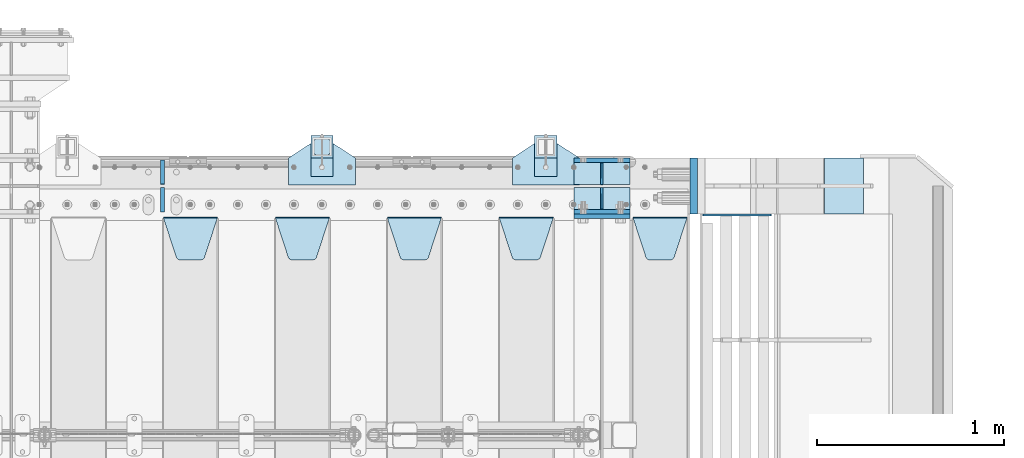
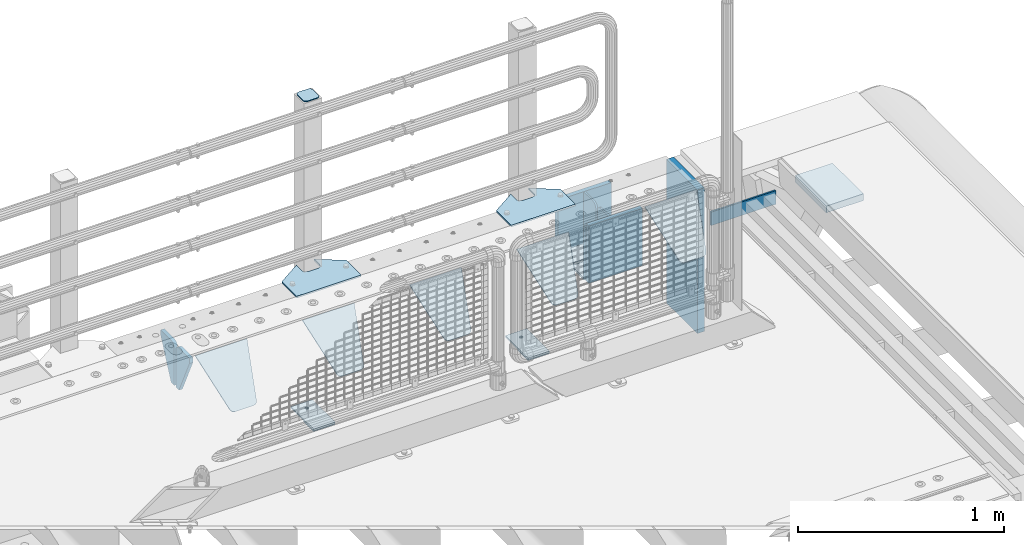
# One storey, part 179 of 193: 24 plates.
"""IFC2X3 building model written with IfcOpenShell, lengths in millimetres."""

from ifc_helpers import new_model, si_unit, frame, origin_with_axes, place, context, subcontext, project, spatial, faceted_brep, material, type_object, element, save


model = new_model("IFC2X3")

# Units and contexts
model_context = context("Model", 3, precision=1e-05, world=origin_with_axes())
body_context = subcontext(model_context, "Body", "Model", "MODEL_VIEW")
ifc_project = project(units=[si_unit("LENGTHUNIT", "METRE", prefix="MILLI"), si_unit("AREAUNIT", "SQUARE_METRE"), si_unit("VOLUMEUNIT", "CUBIC_METRE"), si_unit("MASSUNIT", "GRAM", prefix="KILO"), si_unit("TIMEUNIT", "SECOND"), si_unit("PLANEANGLEUNIT", "RADIAN"), si_unit("SOLIDANGLEUNIT", "STERADIAN"), si_unit("THERMODYNAMICTEMPERATUREUNIT", "DEGREE_CELSIUS"), si_unit("LUMINOUSINTENSITYUNIT", "LUMEN")], contexts=[model_context])

# Site, building, storey
site_placement = place(None, origin_with_axes())
site = spatial("IfcSite", under=ifc_project, at=site_placement, CompositionType="ELEMENT")
building_placement = place(site_placement, origin_with_axes())
building = spatial("IfcBuilding", under=site, at=building_placement, Name="Standard", CompositionType="ELEMENT")
storey_placement = place(building_placement, origin_with_axes())
storey = spatial("IfcBuildingStorey", under=building, at=storey_placement, Name="Undefined", CompositionType="ELEMENT", Elevation=0.0)

# Plates
ifc_material_1 = material(Name="STEEL/S355N")
plate_type_1 = type_object("IfcPlateType", PredefinedType="NOTDEFINED")
for number, where, z_axis, x_axis in (
    (1, (-29045.0, 30137.5, -339.999999999995), (0.0, 0.0, 1.0), (1.0, 0.0, 0.0)),
    (2, (-29045.0, 29862.5, -339.999999999995), (0.0, 0.0, 1.0), (1.0, 0.0, 0.0)),
):
    element("IfcPlate", number, at=place(storey_placement, frame(where, z_axis=z_axis, x_axis=x_axis)), inside=storey, type_object=plate_type_1, material=ifc_material_1, context=body_context, shape_type="Brep", body=[
        faceted_brep([(0.0, -12.5, 0.0), (0.0, -12.5, 310.0), (0.0, 12.5, 310.0), (0.0, 12.5, 0.0), (300.0, -12.5, 310.0), (300.0, 12.5, 310.0), (300.0, -12.5, 0.0), (300.0, 12.5, 0.0)], [[[0, 1, 2, 3]], [[1, 4, 5, 2]], [[4, 6, 7, 5]], [[6, 0, 3, 7]], [[5, 7, 3, 2]], [[6, 4, 1, 0]]]),
    ])
plate_1_placement = place(storey_placement, frame((-29045.0, 29837.5, -340.000000000044), z_axis=(0.0, 0.0, 1.0), x_axis=(1.0, 0.0, 0.0)))
element("IfcPlate", 3, at=plate_1_placement, inside=storey, type_object=plate_type_1, material=ifc_material_1, context=body_context, shape_type="Brep", body=[
    faceted_brep([(0.0, -12.5, 0.0), (9.27684595808387e-10, -12.5, 340.0), (9.27684595808387e-10, 12.5, 340.0), (0.0, 12.5, 0.0), (300.0, -12.5, 340.0), (300.0, 12.5, 340.0), (300.0, -12.5, 0.0), (300.0, 12.5, 0.0)], [[[0, 1, 2, 3]], [[1, 4, 5, 2]], [[4, 6, 7, 5]], [[6, 0, 3, 7]], [[5, 7, 3, 2]], [[6, 4, 1, 0]]]),
])
plate_type_2 = type_object("IfcPlateType", PredefinedType="NOTDEFINED")
for number, where, z_axis, x_axis in (
    (4, (-29045.0, 30008.0, -342.999999999995), (0.0, 1.0, 0.0), (1.0, 0.0, 0.0)),
    (5, (-29045.0, 29992.0, -342.999999999995), (0.0, -1.0, 0.0), (1.0, 0.0, 0.0)),
):
    element("IfcPlate", number, at=place(storey_placement, frame(where, z_axis=z_axis, x_axis=x_axis)), inside=storey, type_object=plate_type_2, material=ifc_material_1, context=body_context, shape_type="Brep", body=[
        faceted_brep([(0.0, -7.0, 0.0), (0.0, -7.0, 117.0), (0.0, 7.0, 117.0), (0.0, 7.0, 0.0), (300.0, -7.0, 117.0), (300.0, 7.0, 117.0), (300.0, -7.0, 0.0), (300.0, 7.0, 0.0)], [[[0, 1, 2, 3]], [[1, 4, 5, 2]], [[4, 6, 7, 5]], [[6, 0, 3, 7]], [[5, 7, 3, 2]], [[6, 4, 1, 0]]]),
    ])
plate_type_3 = type_object("IfcPlateType", PredefinedType="NOTDEFINED")
for number, where, z_axis, x_axis in (
    (6, (-28895.0, 30008.0, -29.9999999999945), (0.0, 0.0, -1.0), (0.0, 1.0, 0.0)),
    (7, (-28895.0, 29992.0, -29.9999999999945), (0.0, 0.0, -1.0), (0.0, -1.0, 0.0)),
):
    element("IfcPlate", number, at=place(storey_placement, frame(where, z_axis=z_axis, x_axis=x_axis)), inside=storey, type_object=plate_type_3, material=ifc_material_1, context=body_context, shape_type="Brep", body=[
        faceted_brep([(0.0, -5.0, 30.0), (0.0, -5.0, 306.0), (0.0, 5.0, 306.0), (0.0, 5.0, 30.0), (117.0, -5.0, 306.0), (117.0, 5.0, 306.0), (117.0, -5.0, 0.0), (117.0, 5.0, 0.0), (30.0, -5.0, 0.0), (30.0, 5.0, 0.0), (24.7905546699913, -5.0, 0.455767409633758), (24.7905546699913, 5.0, 0.455767409633758), (19.7393957002314, -5.0, 1.80922137642275), (19.7393957002314, 5.0, 1.80922137642275), (15.0, -5.0, 4.01923788646684), (15.0, 5.0, 4.01923788646684), (10.7163717094045, -5.0, 7.01866670643066), (10.7163717094045, 5.0, 7.01866670643066), (7.01866670642994, -5.0, 10.7163717094038), (7.01866670642994, 5.0, 10.7163717094038), (4.01923788646673, -5.0, 15.0), (4.01923788646673, 5.0, 15.0), (1.80922137642119, -5.0, 19.7393957002299), (1.80922137642119, 5.0, 19.7393957002299), (0.455767409632244, -5.0, 24.7905546699921), (0.455767409632244, 5.0, 24.7905546699921)], [[[0, 1, 2, 3]], [[1, 4, 5, 2]], [[4, 6, 7, 5]], [[6, 8, 9, 7]], [[8, 10, 11, 9]], [[10, 12, 13, 11]], [[12, 14, 15, 13]], [[14, 16, 17, 15]], [[16, 18, 19, 17]], [[18, 20, 21, 19]], [[20, 22, 23, 21]], [[22, 24, 25, 23]], [[24, 0, 3, 25]], [[5, 7, 9, 11, 13, 15, 17, 19, 21, 23, 25, 3, 2]], [[24, 22, 20, 18, 16, 14, 12, 10, 8, 6, 4, 1, 0]]]),
    ])
plate_type_4 = type_object("IfcPlateType", PredefinedType="NOTDEFINED")
plate_2_placement = place(storey_placement, frame((-28728.0, 29831.767766956, -1.76776695296758), z_axis=(0.0, -0.707106781186547, -0.707106781186548), x_axis=(1.0, 0.0, 0.0)))
element("IfcPlate", 8, at=plate_2_placement, inside=storey, type_object=plate_type_4, material=ifc_material_1, context=body_context, shape_type="Brep", body=[
    faceted_brep([(0.0, -2.5, 0.0), (69.345504679477, -2.50000000000364, 300.171731424831), (69.345504679477, 2.49999999999636, 300.171731424831), (0.0, 2.5, 0.0), (70.9274061199576, -2.50000000000364, 304.897442415397), (70.9274061199576, 2.49999999999636, 304.897442415397), (73.3818627772307, -2.50000000000364, 309.234538108529), (73.3818627772307, 2.49999999999636, 309.234538108529), (76.6187032999551, -2.50000000000728, 313.023683126103), (76.6187032999551, 2.49999999999636, 313.023683126103), (80.5190132704993, -2.50000000000364, 316.125672595372), (80.5190132704993, 2.49999999999636, 316.125672595368), (84.9395038596849, -2.50000000000364, 318.426546230472), (84.9395038596849, 2.49999999999636, 318.426546230476), (89.7177759439219, -2.50000000000364, 319.841774983273), (89.7177759439219, 2.49999999999636, 319.841774983277), (94.678286292652, -2.50000000000364, 320.319366455074), (94.678286292652, 2.49999999999636, 320.319366455074), (195.321713707348, -2.50000000000364, 320.319366455074), (195.321713707348, 2.49999999999636, 320.319366455074), (200.282224056078, -2.50000000000364, 319.841774983273), (200.282224056078, 2.49999999999636, 319.841774983277), (205.060496140315, -2.50000000000364, 318.426546230472), (205.060496140315, 2.49999999999636, 318.426546230472), (209.480986729501, -2.50000000000364, 316.125672595372), (209.480986729501, 2.49999999999636, 316.125672595368), (213.381296700045, -2.50000000000728, 313.023683126103), (213.381296700045, 2.49999999999272, 313.023683126103), (216.618137222769, -2.50000000000364, 309.234538108525), (216.618137222769, 2.49999999999636, 309.234538108522), (219.072593880042, -2.50000000000364, 304.897442415397), (219.072593880042, 2.49999999999636, 304.897442415397), (220.654495320523, -2.50000000000364, 300.171731424831), (220.654495320523, 2.49999999999636, 300.171731424831), (290.0, -2.50000000000364, 0.0), (290.0, 2.49999999999636, 0.0)], [[[0, 1, 2, 3]], [[1, 4, 5, 2]], [[4, 6, 7, 5]], [[6, 8, 9, 7]], [[8, 10, 11, 9]], [[10, 12, 13, 11]], [[12, 14, 15, 13]], [[14, 16, 17, 15]], [[16, 18, 19, 17]], [[18, 20, 21, 19]], [[20, 22, 23, 21]], [[22, 24, 25, 23]], [[24, 26, 27, 25]], [[26, 28, 29, 27]], [[28, 30, 31, 29]], [[30, 32, 33, 31]], [[32, 34, 35, 33]], [[34, 0, 3, 35]], [[5, 7, 9, 11, 13, 15, 17, 19, 21, 23, 25, 27, 29, 31, 33, 35, 3, 2]], [[34, 32, 30, 28, 26, 24, 22, 20, 18, 16, 14, 12, 10, 8, 6, 4, 1, 0]]]),
])
plate_3_placement = place(storey_placement, frame((-29445.0, 29831.767766956, -1.76776695296758), z_axis=(0.0, -0.707106781186547, -0.707106781186548), x_axis=(1.0, 0.0, 0.0)))
element("IfcPlate", 9, at=plate_3_placement, inside=storey, type_object=plate_type_4, material=ifc_material_1, context=body_context, shape_type="Brep", body=[
    faceted_brep([(0.0, -2.5, 0.0), (69.345504679477, -2.50000000000364, 300.171731424831), (69.345504679477, 2.49999999999636, 300.171731424831), (0.0, 2.5, 0.0), (70.9274061199576, -2.50000000000364, 304.897442415397), (70.9274061199576, 2.49999999999636, 304.897442415397), (73.3818627772307, -2.50000000000364, 309.234538108529), (73.3818627772307, 2.49999999999636, 309.234538108529), (76.6187032999551, -2.50000000000728, 313.023683126103), (76.6187032999551, 2.49999999999636, 313.023683126103), (80.5190132704993, -2.50000000000364, 316.125672595372), (80.5190132704993, 2.49999999999636, 316.125672595368), (84.9395038596849, -2.50000000000364, 318.426546230472), (84.9395038596849, 2.49999999999636, 318.426546230476), (89.7177759439219, -2.50000000000364, 319.841774983273), (89.7177759439219, 2.49999999999636, 319.841774983277), (94.678286292652, -2.50000000000364, 320.319366455074), (94.678286292652, 2.49999999999636, 320.319366455074), (195.321713707348, -2.50000000000364, 320.319366455074), (195.321713707348, 2.49999999999636, 320.319366455074), (200.282224056078, -2.50000000000364, 319.841774983273), (200.282224056078, 2.49999999999636, 319.841774983277), (205.060496140315, -2.50000000000364, 318.426546230472), (205.060496140315, 2.49999999999636, 318.426546230472), (209.480986729501, -2.50000000000364, 316.125672595372), (209.480986729501, 2.49999999999636, 316.125672595368), (213.381296700045, -2.50000000000728, 313.023683126103), (213.381296700045, 2.49999999999272, 313.023683126103), (216.618137222769, -2.50000000000364, 309.234538108525), (216.618137222769, 2.49999999999636, 309.234538108522), (219.072593880042, -2.50000000000364, 304.897442415397), (219.072593880042, 2.49999999999636, 304.897442415397), (220.654495320523, -2.50000000000364, 300.171731424831), (220.654495320523, 2.49999999999636, 300.171731424831), (290.0, -2.50000000000364, 0.0), (290.0, 2.49999999999636, 0.0)], [[[0, 1, 2, 3]], [[1, 4, 5, 2]], [[4, 6, 7, 5]], [[6, 8, 9, 7]], [[8, 10, 11, 9]], [[10, 12, 13, 11]], [[12, 14, 15, 13]], [[14, 16, 17, 15]], [[16, 18, 19, 17]], [[18, 20, 21, 19]], [[20, 22, 23, 21]], [[22, 24, 25, 23]], [[24, 26, 27, 25]], [[26, 28, 29, 27]], [[28, 30, 31, 29]], [[30, 32, 33, 31]], [[32, 34, 35, 33]], [[34, 0, 3, 35]], [[5, 7, 9, 11, 13, 15, 17, 19, 21, 23, 25, 27, 29, 31, 33, 35, 3, 2]], [[34, 32, 30, 28, 26, 24, 22, 20, 18, 16, 14, 12, 10, 8, 6, 4, 1, 0]]]),
])
plate_4_placement = place(storey_placement, frame((-30045.0, 29831.767766956, -1.76776695296758), z_axis=(0.0, -0.707106781186547, -0.707106781186548), x_axis=(1.0, 0.0, 0.0)))
element("IfcPlate", 10, at=plate_4_placement, inside=storey, type_object=plate_type_4, material=ifc_material_1, context=body_context, shape_type="Brep", body=[
    faceted_brep([(0.0, -2.5, 0.0), (69.345504679477, -2.50000000000364, 300.171731424831), (69.345504679477, 2.49999999999636, 300.171731424831), (0.0, 2.5, 0.0), (70.9274061199576, -2.50000000000364, 304.897442415397), (70.9274061199576, 2.49999999999636, 304.897442415397), (73.3818627772307, -2.50000000000364, 309.234538108529), (73.3818627772307, 2.49999999999636, 309.234538108529), (76.6187032999551, -2.50000000000728, 313.023683126103), (76.6187032999551, 2.49999999999636, 313.023683126103), (80.5190132704993, -2.50000000000364, 316.125672595372), (80.5190132704993, 2.49999999999636, 316.125672595368), (84.9395038596849, -2.50000000000364, 318.426546230472), (84.9395038596849, 2.49999999999636, 318.426546230476), (89.7177759439219, -2.50000000000364, 319.841774983273), (89.7177759439219, 2.49999999999636, 319.841774983277), (94.678286292652, -2.50000000000364, 320.319366455074), (94.678286292652, 2.49999999999636, 320.319366455074), (195.321713707348, -2.50000000000364, 320.319366455074), (195.321713707348, 2.49999999999636, 320.319366455074), (200.282224056078, -2.50000000000364, 319.841774983273), (200.282224056078, 2.49999999999636, 319.841774983277), (205.060496140315, -2.50000000000364, 318.426546230472), (205.060496140315, 2.49999999999636, 318.426546230472), (209.480986729501, -2.50000000000364, 316.125672595372), (209.480986729501, 2.49999999999636, 316.125672595368), (213.381296700045, -2.50000000000728, 313.023683126103), (213.381296700045, 2.49999999999272, 313.023683126103), (216.618137222769, -2.50000000000364, 309.234538108525), (216.618137222769, 2.49999999999636, 309.234538108522), (219.072593880042, -2.50000000000364, 304.897442415397), (219.072593880042, 2.49999999999636, 304.897442415397), (220.654495320523, -2.50000000000364, 300.171731424831), (220.654495320523, 2.49999999999636, 300.171731424831), (290.0, -2.50000000000364, 0.0), (290.0, 2.49999999999636, 0.0)], [[[0, 1, 2, 3]], [[1, 4, 5, 2]], [[4, 6, 7, 5]], [[6, 8, 9, 7]], [[8, 10, 11, 9]], [[10, 12, 13, 11]], [[12, 14, 15, 13]], [[14, 16, 17, 15]], [[16, 18, 19, 17]], [[18, 20, 21, 19]], [[20, 22, 23, 21]], [[22, 24, 25, 23]], [[24, 26, 27, 25]], [[26, 28, 29, 27]], [[28, 30, 31, 29]], [[30, 32, 33, 31]], [[32, 34, 35, 33]], [[34, 0, 3, 35]], [[5, 7, 9, 11, 13, 15, 17, 19, 21, 23, 25, 27, 29, 31, 33, 35, 3, 2]], [[34, 32, 30, 28, 26, 24, 22, 20, 18, 16, 14, 12, 10, 8, 6, 4, 1, 0]]]),
])
plate_5_placement = place(storey_placement, frame((-30645.0, 29831.767766956, -1.76776695296758), z_axis=(0.0, -0.707106781186547, -0.707106781186548), x_axis=(1.0, 0.0, 0.0)))
element("IfcPlate", 11, at=plate_5_placement, inside=storey, type_object=plate_type_4, material=ifc_material_1, context=body_context, shape_type="Brep", body=[
    faceted_brep([(0.0, -2.5, 0.0), (69.345504679477, -2.50000000000364, 300.171731424831), (69.345504679477, 2.49999999999636, 300.171731424831), (0.0, 2.5, 0.0), (70.9274061199576, -2.50000000000364, 304.897442415397), (70.9274061199576, 2.49999999999636, 304.897442415397), (73.3818627772307, -2.50000000000364, 309.234538108529), (73.3818627772307, 2.49999999999636, 309.234538108529), (76.6187032999551, -2.50000000000728, 313.023683126103), (76.6187032999551, 2.49999999999636, 313.023683126103), (80.5190132704993, -2.50000000000364, 316.125672595372), (80.5190132704993, 2.49999999999636, 316.125672595368), (84.9395038596849, -2.50000000000364, 318.426546230472), (84.9395038596849, 2.49999999999636, 318.426546230476), (89.7177759439219, -2.50000000000364, 319.841774983273), (89.7177759439219, 2.49999999999636, 319.841774983277), (94.678286292652, -2.50000000000364, 320.319366455074), (94.678286292652, 2.49999999999636, 320.319366455074), (195.321713707348, -2.50000000000364, 320.319366455074), (195.321713707348, 2.49999999999636, 320.319366455074), (200.282224056078, -2.50000000000364, 319.841774983273), (200.282224056078, 2.49999999999636, 319.841774983277), (205.060496140315, -2.50000000000364, 318.426546230472), (205.060496140315, 2.49999999999636, 318.426546230472), (209.480986729501, -2.50000000000364, 316.125672595372), (209.480986729501, 2.49999999999636, 316.125672595368), (213.381296700045, -2.50000000000728, 313.023683126103), (213.381296700045, 2.49999999999272, 313.023683126103), (216.618137222769, -2.50000000000364, 309.234538108525), (216.618137222769, 2.49999999999636, 309.234538108522), (219.072593880042, -2.50000000000364, 304.897442415397), (219.072593880042, 2.49999999999636, 304.897442415397), (220.654495320523, -2.50000000000364, 300.171731424831), (220.654495320523, 2.49999999999636, 300.171731424831), (290.0, -2.50000000000364, 0.0), (290.0, 2.49999999999636, 0.0)], [[[0, 1, 2, 3]], [[1, 4, 5, 2]], [[4, 6, 7, 5]], [[6, 8, 9, 7]], [[8, 10, 11, 9]], [[10, 12, 13, 11]], [[12, 14, 15, 13]], [[14, 16, 17, 15]], [[16, 18, 19, 17]], [[18, 20, 21, 19]], [[20, 22, 23, 21]], [[22, 24, 25, 23]], [[24, 26, 27, 25]], [[26, 28, 29, 27]], [[28, 30, 31, 29]], [[30, 32, 33, 31]], [[32, 34, 35, 33]], [[34, 0, 3, 35]], [[5, 7, 9, 11, 13, 15, 17, 19, 21, 23, 25, 27, 29, 31, 33, 35, 3, 2]], [[34, 32, 30, 28, 26, 24, 22, 20, 18, 16, 14, 12, 10, 8, 6, 4, 1, 0]]]),
])
plate_6_placement = place(storey_placement, frame((-31245.0, 29831.767766956, -1.76776695296758), z_axis=(0.0, -0.707106781186547, -0.707106781186548), x_axis=(1.0, 0.0, 0.0)))
element("IfcPlate", 12, at=plate_6_placement, inside=storey, type_object=plate_type_4, material=ifc_material_1, context=body_context, shape_type="Brep", body=[
    faceted_brep([(0.0, -2.5, 0.0), (69.345504679477, -2.50000000000364, 300.171731424831), (69.345504679477, 2.49999999999636, 300.171731424831), (0.0, 2.5, 0.0), (70.9274061199576, -2.50000000000364, 304.897442415397), (70.9274061199576, 2.49999999999636, 304.897442415397), (73.3818627772307, -2.50000000000364, 309.234538108529), (73.3818627772307, 2.49999999999636, 309.234538108529), (76.6187032999551, -2.50000000000728, 313.023683126103), (76.6187032999551, 2.49999999999636, 313.023683126103), (80.5190132704993, -2.50000000000364, 316.125672595372), (80.5190132704993, 2.49999999999636, 316.125672595368), (84.9395038596849, -2.50000000000364, 318.426546230472), (84.9395038596849, 2.49999999999636, 318.426546230476), (89.7177759439219, -2.50000000000364, 319.841774983273), (89.7177759439219, 2.49999999999636, 319.841774983277), (94.678286292652, -2.50000000000364, 320.319366455074), (94.678286292652, 2.49999999999636, 320.319366455074), (195.321713707348, -2.50000000000364, 320.319366455074), (195.321713707348, 2.49999999999636, 320.319366455074), (200.282224056078, -2.50000000000364, 319.841774983273), (200.282224056078, 2.49999999999636, 319.841774983277), (205.060496140315, -2.50000000000364, 318.426546230472), (205.060496140315, 2.49999999999636, 318.426546230472), (209.480986729501, -2.50000000000364, 316.125672595372), (209.480986729501, 2.49999999999636, 316.125672595368), (213.381296700045, -2.50000000000728, 313.023683126103), (213.381296700045, 2.49999999999272, 313.023683126103), (216.618137222769, -2.50000000000364, 309.234538108525), (216.618137222769, 2.49999999999636, 309.234538108522), (219.072593880042, -2.50000000000364, 304.897442415397), (219.072593880042, 2.49999999999636, 304.897442415397), (220.654495320523, -2.50000000000364, 300.171731424831), (220.654495320523, 2.49999999999636, 300.171731424831), (290.0, -2.50000000000364, 0.0), (290.0, 2.49999999999636, 0.0)], [[[0, 1, 2, 3]], [[1, 4, 5, 2]], [[4, 6, 7, 5]], [[6, 8, 9, 7]], [[8, 10, 11, 9]], [[10, 12, 13, 11]], [[12, 14, 15, 13]], [[14, 16, 17, 15]], [[16, 18, 19, 17]], [[18, 20, 21, 19]], [[20, 22, 23, 21]], [[22, 24, 25, 23]], [[24, 26, 27, 25]], [[26, 28, 29, 27]], [[28, 30, 31, 29]], [[30, 32, 33, 31]], [[32, 34, 35, 33]], [[34, 0, 3, 35]], [[5, 7, 9, 11, 13, 15, 17, 19, 21, 23, 25, 27, 29, 31, 33, 35, 3, 2]], [[34, 32, 30, 28, 26, 24, 22, 20, 18, 16, 14, 12, 10, 8, 6, 4, 1, 0]]]),
])
plate_type_5 = type_object("IfcPlateType", PredefinedType="NOTDEFINED")
for number, where, z_axis, x_axis in (
    (13, (-31250.0, 30140.0, -30.0), (0.0, 0.0, -1.0), (0.0, -1.0, 0.0)),
    (14, (-31250.0, 29860.0, -30.0), (0.0, 0.0, -1.0), (0.0, 1.0, 0.0)),
):
    element("IfcPlate", number, at=place(storey_placement, frame(where, z_axis=z_axis, x_axis=x_axis)), inside=storey, type_object=plate_type_5, material=ifc_material_1, context=body_context, shape_type="Brep", body=[
        faceted_brep([(0.0, -10.0, 0.0), (0.0, -10.0, 30.0), (0.0, 10.0, 30.0), (0.0, 10.0, 0.0), (102.0, -10.0, 250.0), (102.0, 10.0, 250.0), (132.0, -10.0, 250.0), (132.0, 10.0, 250.0), (132.0, -10.0, 30.0), (132.0, 10.0, 30.0), (131.544232590368, -10.0, 24.790554669992), (131.544232590368, 10.0, 24.790554669992), (130.190778623579, -10.0, 19.7393957002299), (130.190778623579, 10.0, 19.7393957002299), (127.980762113533, -10.0, 15.0), (127.980762113533, 10.0, 15.0), (124.98133329357, -10.0, 10.7163717094038), (124.98133329357, 10.0, 10.7163717094038), (121.283628290596, -10.0, 7.01866670643062), (121.283628290596, 10.0, 7.01866670643062), (117.0, -10.0, 4.01923788646684), (117.0, 10.0, 4.01923788646684), (112.260604299769, -10.0, 1.80922137642278), (112.260604299769, 10.0, 1.80922137642278), (107.209445330009, -10.0, 0.455767409633722), (107.209445330009, 10.0, 0.455767409633722), (102.0, -10.0, 0.0), (102.0, 10.0, 0.0)], [[[0, 1, 2, 3]], [[1, 4, 5, 2]], [[4, 6, 7, 5]], [[6, 8, 9, 7]], [[8, 10, 11, 9]], [[10, 12, 13, 11]], [[12, 14, 15, 13]], [[14, 16, 17, 15]], [[16, 18, 19, 17]], [[18, 20, 21, 19]], [[20, 22, 23, 21]], [[22, 24, 25, 23]], [[24, 26, 27, 25]], [[26, 0, 3, 27]], [[5, 7, 9, 11, 13, 15, 17, 19, 21, 23, 25, 27, 3, 2]], [[26, 24, 22, 20, 18, 16, 14, 12, 10, 8, 6, 4, 1, 0]]]),
    ])
ifc_material_2 = material(Name="STEEL/S355J2")
plate_type_6 = type_object("IfcPlateType", PredefinedType="NOTDEFINED")
plate_7_placement = place(storey_placement, frame((-29375.0, 30005.0, 5.00000000004911), z_axis=(0.0, 1.0, 0.0), x_axis=(1.0, 0.0, 0.0)))
element("IfcPlate", 15, at=plate_7_placement, inside=storey, type_object=plate_type_6, material=ifc_material_2, context=body_context, shape_type="Brep", body=[
    faceted_brep([(0.0, -5.0, 0.0), (2.31396552408114e-06, -5.0, 145.0), (2.31396552408114e-06, 5.0, 145.0), (0.0, 5.0, 0.0), (130.0, -5.0, 230.0), (130.0, 5.0, 230.0), (130.0, -5.0, 180.0), (130.0, 5.0, 180.0), (130.48036798992, -5.0, 175.122741949595), (130.48036798992, 5.0, 175.122741949595), (131.903011687216, -5.0, 170.432914190871), (131.903011687216, 5.0, 170.432914190871), (134.213259692435, -5.0, 166.110744174512), (134.213259692435, 5.0, 166.110744174512), (137.322330470335, -5.0, 162.322330470335), (137.322330470335, 5.0, 162.322330470335), (141.110744174512, -5.0, 159.213259692435), (141.110744174512, 5.0, 159.213259692435), (145.432914190871, -5.0, 156.903011687216), (145.432914190871, 5.0, 156.903011687216), (150.122741949595, -5.0, 155.48036798992), (150.122741949595, 5.0, 155.48036798992), (155.0, -5.0, 155.0), (155.0, 5.0, 155.0), (205.0, -5.0, 155.0), (205.0, 5.0, 155.0), (209.877258050405, -5.0, 155.48036798992), (209.877258050405, 5.0, 155.48036798992), (214.567085809129, -5.0, 156.903011687216), (214.567085809129, 5.0, 156.903011687216), (218.889255825488, -5.0, 159.213259692435), (218.889255825488, 5.0, 159.213259692435), (222.677669529665, -5.0, 162.322330470335), (222.677669529665, 5.0, 162.322330470335), (225.786740307565, -5.0, 166.110744174512), (225.786740307565, 5.0, 166.110744174512), (228.096988312784, -5.0, 170.432914190871), (228.096988312784, 5.0, 170.432914190871), (229.51963201008, -5.0, 175.122741949595), (229.51963201008, 5.0, 175.122741949595), (230.0, -5.0, 180.0), (230.0, 5.0, 180.0), (230.0, -5.0, 230.0), (230.0, 5.0, 230.0), (360.0, -5.0, 145.0), (360.0, 5.0, 145.0), (360.0, -5.0, -7.27595761418343e-12), (360.0, 5.0, -7.27595761418343e-12)], [[[0, 1, 2, 3]], [[1, 4, 5, 2]], [[4, 6, 7, 5]], [[6, 8, 9, 7]], [[8, 10, 11, 9]], [[10, 12, 13, 11]], [[12, 14, 15, 13]], [[14, 16, 17, 15]], [[16, 18, 19, 17]], [[18, 20, 21, 19]], [[20, 22, 23, 21]], [[22, 24, 25, 23]], [[24, 26, 27, 25]], [[26, 28, 29, 27]], [[28, 30, 31, 29]], [[30, 32, 33, 31]], [[32, 34, 35, 33]], [[34, 36, 37, 35]], [[36, 38, 39, 37]], [[38, 40, 41, 39]], [[40, 42, 43, 41]], [[42, 44, 45, 43]], [[44, 46, 47, 45]], [[46, 0, 3, 47]], [[5, 7, 9, 11, 13, 15, 17, 19, 21, 23, 25, 27, 29, 31, 33, 35, 37, 39, 41, 43, 45, 47, 3, 2]], [[46, 44, 42, 40, 38, 36, 34, 32, 30, 28, 26, 24, 22, 20, 18, 16, 14, 12, 10, 8, 6, 4, 1, 0]]]),
])
plate_8_placement = place(storey_placement, frame((-30575.0, 30005.0, 5.00000000004911), z_axis=(0.0, 1.0, 0.0), x_axis=(1.0, 0.0, 0.0)))
element("IfcPlate", 16, at=plate_8_placement, inside=storey, type_object=plate_type_6, material=ifc_material_2, context=body_context, shape_type="Brep", body=[
    faceted_brep([(0.0, -5.0, 0.0), (2.31396552408114e-06, -5.0, 145.0), (2.31396552408114e-06, 5.0, 145.0), (0.0, 5.0, 0.0), (130.0, -5.0, 230.0), (130.0, 5.0, 230.0), (130.0, -5.0, 180.0), (130.0, 5.0, 180.0), (130.48036798992, -5.0, 175.122741949595), (130.48036798992, 5.0, 175.122741949595), (131.903011687216, -5.0, 170.432914190871), (131.903011687216, 5.0, 170.432914190871), (134.213259692435, -5.0, 166.110744174512), (134.213259692435, 5.0, 166.110744174512), (137.322330470335, -5.0, 162.322330470335), (137.322330470335, 5.0, 162.322330470335), (141.110744174512, -5.0, 159.213259692435), (141.110744174512, 5.0, 159.213259692435), (145.432914190871, -5.0, 156.903011687216), (145.432914190871, 5.0, 156.903011687216), (150.122741949595, -5.0, 155.48036798992), (150.122741949595, 5.0, 155.48036798992), (155.0, -5.0, 155.0), (155.0, 5.0, 155.0), (205.0, -5.0, 155.0), (205.0, 5.0, 155.0), (209.877258050405, -5.0, 155.48036798992), (209.877258050405, 5.0, 155.48036798992), (214.567085809129, -5.0, 156.903011687216), (214.567085809129, 5.0, 156.903011687216), (218.889255825488, -5.0, 159.213259692435), (218.889255825488, 5.0, 159.213259692435), (222.677669529665, -5.0, 162.322330470335), (222.677669529665, 5.0, 162.322330470335), (225.786740307565, -5.0, 166.110744174512), (225.786740307565, 5.0, 166.110744174512), (228.096988312784, -5.0, 170.432914190871), (228.096988312784, 5.0, 170.432914190871), (229.51963201008, -5.0, 175.122741949595), (229.51963201008, 5.0, 175.122741949595), (230.0, -5.0, 180.0), (230.0, 5.0, 180.0), (230.0, -5.0, 230.0), (230.0, 5.0, 230.0), (360.0, -5.0, 145.0), (360.0, 5.0, 145.0), (360.0, -5.0, -7.27595761418343e-12), (360.0, 5.0, -7.27595761418343e-12)], [[[0, 1, 2, 3]], [[1, 4, 5, 2]], [[4, 6, 7, 5]], [[6, 8, 9, 7]], [[8, 10, 11, 9]], [[10, 12, 13, 11]], [[12, 14, 15, 13]], [[14, 16, 17, 15]], [[16, 18, 19, 17]], [[18, 20, 21, 19]], [[20, 22, 23, 21]], [[22, 24, 25, 23]], [[24, 26, 27, 25]], [[26, 28, 29, 27]], [[28, 30, 31, 29]], [[30, 32, 33, 31]], [[32, 34, 35, 33]], [[34, 36, 37, 35]], [[36, 38, 39, 37]], [[38, 40, 41, 39]], [[40, 42, 43, 41]], [[42, 44, 45, 43]], [[44, 46, 47, 45]], [[46, 0, 3, 47]], [[5, 7, 9, 11, 13, 15, 17, 19, 21, 23, 25, 27, 29, 31, 33, 35, 37, 39, 41, 43, 45, 47, 3, 2]], [[46, 44, 42, 40, 38, 36, 34, 32, 30, 28, 26, 24, 22, 20, 18, 16, 14, 12, 10, 8, 6, 4, 1, 0]]]),
])
plate_type_7 = type_object("IfcPlateType", PredefinedType="NOTDEFINED")
for number, where, z_axis, x_axis in (
    (17, (-29254.9999999999, 30050.0000000002, -850.000000000002), (0.0, 1.0, 0.0), (1.0, 0.0, 0.0)),
    (18, (-30454.9999999999, 30050.0000000002, -850.000000000002), (0.0, 1.0, 0.0), (1.0, 0.0, 0.0)),
):
    element("IfcPlate", number, at=place(storey_placement, frame(where, z_axis=z_axis, x_axis=x_axis)), inside=storey, type_object=plate_type_7, material=ifc_material_2, context=body_context, shape_type="Brep", body=[
        faceted_brep([(66.3639610305399, -5.0, 163.636038969111), (66.3639610305399, 5.0, 163.636038969111), (59.9999999998618, 5.0, 160.999999999789), (59.9999999998618, -5.0, 160.999999999789), (53.6360389691836, 5.0, 163.636038969111), (53.6360389691836, -5.0, 163.636038969111), (50.9999999998618, 5.0, 169.999999999789), (50.9999999998618, -5.0, 169.999999999789), (53.6360389691836, 5.0, 176.363961030467), (53.6360389691836, -5.0, 176.363961030467), (59.9999999998618, 5.0, 178.999999999789), (59.9999999998618, -5.0, 178.999999999789), (66.3639610305399, 5.0, 176.363961030467), (66.3639610305399, -5.0, 176.363961030467), (68.9999999998618, 5.0, 169.999999999789), (68.9999999998618, -5.0, 169.999999999789), (120.0, -5.0, 0.0), (120.0, -5.0, 220.0), (0.0, -5.0, 220.0), (0.0, -5.0, 0.0), (0.0, 5.0, 0.0), (120.0, 5.0, 0.0), (120.0, 5.0, 220.0), (0.0, 5.0, 220.0)], [[[0, 1, 2, 3]], [[3, 2, 4, 5]], [[5, 4, 6, 7]], [[7, 6, 8, 9]], [[9, 8, 10, 11]], [[11, 10, 12, 13]], [[13, 12, 14, 15]], [[15, 14, 1, 0]], [[16, 17, 18, 19], [3, 5, 7, 9, 11, 13, 15, 0]], [[16, 19, 20, 21]], [[17, 16, 21, 22]], [[18, 17, 22, 23]], [[19, 18, 23, 20]], [[22, 21, 20, 23], [10, 8, 6, 4, 2, 1, 14, 12]]]),
    ])
plate_type_8 = type_object("IfcPlateType", PredefinedType="NOTDEFINED")
plate_9_placement = place(storey_placement, frame((-30350.9999999999, 30166.0000000002, 1012.50000000001), z_axis=(0.0, 1.0, 0.0), x_axis=(-1.0, 0.0, 0.0)))
element("IfcPlate", 19, at=plate_9_placement, inside=storey, type_object=plate_type_8, material=ifc_material_2, context=body_context, shape_type="Brep", body=[
    faceted_brep([(0.0, -2.5, 19.0), (0.0, -2.5, 69.0), (0.0, 2.5, 69.0), (0.0, 2.5, 19.0), (0.476369668544066, -2.5, 73.2278977451715), (0.476369668544066, 2.5, 73.2278977451715), (1.88159150985302, -2.5, 77.2437910432345), (1.88159150985302, 2.5, 77.2437910432345), (4.14520183310742, -2.5, 80.8463062353148), (4.14520183310742, 2.5, 80.8463062353148), (7.15369376468516, -2.5, 83.8547981668926), (7.15369376468516, 2.5, 83.8547981668926), (10.7562089567655, -2.5, 86.118408490147), (10.7562089567655, 2.5, 86.118408490147), (14.7721022548285, -2.5, 87.5236303314559), (14.7721022548285, 2.5, 87.5236303314559), (19.0, -2.5, 88.0), (19.0, 2.5, 88.0), (69.0, -2.5, 88.0), (69.0, 2.5, 88.0), (73.2278977451715, -2.5, 87.5236303314559), (73.2278977451715, 2.5, 87.5236303314559), (77.2437910432345, -2.5, 86.118408490147), (77.2437910432345, 2.5, 86.118408490147), (80.8463062353148, -2.5, 83.8547981668926), (80.8463062353148, 2.5, 83.8547981668926), (83.8547981668926, -2.5, 80.8463062353148), (83.8547981668926, 2.5, 80.8463062353148), (86.118408490147, -2.5, 77.2437910432345), (86.118408490147, 2.5, 77.2437910432345), (87.5236303314559, -2.5, 73.2278977451715), (87.5236303314559, 2.5, 73.2278977451715), (88.0, -2.5, 69.0), (88.0, 2.5, 69.0), (88.0, -2.5, 19.0), (88.0, 2.5, 19.0), (87.5236303314559, -2.5, 14.7721022548285), (87.5236303314559, 2.5, 14.7721022548285), (86.118408490147, -2.5, 10.7562089567655), (86.118408490147, 2.5, 10.7562089567655), (83.8547981668926, -2.5, 7.15369376468516), (83.8547981668926, 2.5, 7.15369376468516), (80.8463062353148, -2.5, 4.14520183310742), (80.8463062353148, 2.5, 4.14520183310742), (77.2437910432345, -2.5, 1.88159150985302), (77.2437910432345, 2.5, 1.88159150985302), (73.2278977451715, -2.5, 0.476369668544066), (73.2278977451715, 2.5, 0.476369668544066), (69.0, -2.5, 0.0), (69.0, 2.5, 0.0), (19.0, -2.5, 0.0), (19.0, 2.5, 0.0), (14.7721022548285, -2.5, 0.476369668544066), (14.7721022548285, 2.5, 0.476369668544066), (10.7562089567655, -2.5, 1.88159150985302), (10.7562089567655, 2.5, 1.88159150985302), (7.15369376468516, -2.5, 4.14520183310742), (7.15369376468516, 2.5, 4.14520183310742), (4.14520183310742, -2.5, 7.15369376468516), (4.14520183310742, 2.5, 7.15369376468516), (1.88159150985302, -2.5, 10.7562089567655), (1.88159150985302, 2.5, 10.7562089567655), (0.476369668544066, -2.5, 14.7721022548285), (0.476369668544066, 2.5, 14.7721022548285)], [[[0, 1, 2, 3]], [[1, 4, 5, 2]], [[4, 6, 7, 5]], [[6, 8, 9, 7]], [[8, 10, 11, 9]], [[10, 12, 13, 11]], [[12, 14, 15, 13]], [[14, 16, 17, 15]], [[16, 18, 19, 17]], [[18, 20, 21, 19]], [[20, 22, 23, 21]], [[22, 24, 25, 23]], [[24, 26, 27, 25]], [[26, 28, 29, 27]], [[28, 30, 31, 29]], [[30, 32, 33, 31]], [[32, 34, 35, 33]], [[34, 36, 37, 35]], [[36, 38, 39, 37]], [[38, 40, 41, 39]], [[40, 42, 43, 41]], [[42, 44, 45, 43]], [[44, 46, 47, 45]], [[46, 48, 49, 47]], [[48, 50, 51, 49]], [[50, 52, 53, 51]], [[52, 54, 55, 53]], [[54, 56, 57, 55]], [[56, 58, 59, 57]], [[58, 60, 61, 59]], [[60, 62, 63, 61]], [[62, 0, 3, 63]], [[5, 7, 9, 11, 13, 15, 17, 19, 21, 23, 25, 27, 29, 31, 33, 35, 37, 39, 41, 43, 45, 47, 49, 51, 53, 55, 57, 59, 61, 63, 3, 2]], [[62, 60, 58, 56, 54, 52, 50, 48, 46, 44, 42, 40, 38, 36, 34, 32, 30, 28, 26, 24, 22, 20, 18, 16, 14, 12, 10, 8, 6, 4, 1, 0]]]),
])
plate_type_9 = type_object("IfcPlateType", PredefinedType="NOTDEFINED")
for number, where, z_axis, x_axis in (
    (20, (-29254.9999999999, 30050.0000000002, -857.500000000002), (0.0, 1.0, 0.0), (1.0, 0.0, 0.0)),
    (21, (-30454.9999999999, 30050.0000000002, -857.500000000002), (0.0, 1.0, 0.0), (1.0, 0.0, 0.0)),
):
    element("IfcPlate", number, at=place(storey_placement, frame(where, z_axis=z_axis, x_axis=x_axis)), inside=storey, type_object=plate_type_9, material=ifc_material_2, context=body_context, shape_type="Brep", body=[
        faceted_brep([(0.0, -2.5, 0.0), (0.0, -2.5, 100.0), (0.0, 2.5, 100.0), (0.0, 2.5, 0.0), (120.0, -2.5, 100.0), (120.0, 2.5, 100.0), (120.0, -2.5, 0.0), (120.0, 2.5, 0.0)], [[[0, 1, 2, 3]], [[1, 4, 5, 2]], [[4, 6, 7, 5]], [[6, 0, 3, 7]], [[5, 7, 3, 2]], [[6, 4, 1, 0]]]),
    ])
ifc_material_3 = material()
plate_type_10 = type_object("IfcPlateType", PredefinedType="NOTDEFINED")
plate_10_placement = place(storey_placement, frame((-28403.0, 30150.0, -870.0), z_axis=(0.0, 0.0, 1.0), x_axis=(0.0, -1.0, 0.0)))
element("IfcPlate", 22, at=plate_10_placement, inside=storey, type_object=plate_type_10, material=ifc_material_3, context=body_context, shape_type="Brep", body=[
    faceted_brep([(0.0, -20.0, 0.0), (0.0, -20.0, 850.0), (0.0, 20.0, 850.0), (0.0, 20.0, 0.0), (300.0, -20.0, 850.0), (300.0, 20.0, 850.0), (300.0, -20.0, 0.0), (300.0, 20.0, 0.0)], [[[0, 1, 2, 3]], [[1, 4, 5, 2]], [[4, 6, 7, 5]], [[6, 0, 3, 7]], [[5, 7, 3, 2]], [[6, 4, 1, 0]]]),
])
plate_type_11 = type_object("IfcPlateType", PredefinedType="NOTDEFINED")
plate_11_placement = place(storey_placement, frame((-27701.0011701102, 29849.9999999992, -387.999999999302), z_axis=(1.0, 0.0, 0.0), x_axis=(0.0, 1.0, 0.0)))
element("IfcPlate", 23, at=plate_11_placement, inside=storey, type_object=plate_type_11, material=ifc_material_1, context=body_context, shape_type="Brep", body=[
    faceted_brep([(0.0, -20.0, 0.0), (3.31056071445346e-10, -20.0, 208.0), (3.31056071445346e-10, 20.0, 208.0), (0.0, 20.0, 0.0), (300.0, -20.0, 208.0), (300.0, 20.0, 208.0), (300.0, -20.0, 0.0), (300.0, 20.0, 0.0)], [[[0, 1, 2, 3]], [[1, 4, 5, 2]], [[4, 6, 7, 5]], [[6, 0, 3, 7]], [[5, 7, 3, 2]], [[6, 4, 1, 0]]]),
])
plate_type_12 = type_object("IfcPlateType", PredefinedType="NOTDEFINED")
plate_12_placement = place(storey_placement, frame((-27988.001170099, 29844.9999004229, -249.999999999564), z_axis=(-1.0, 0.0, 0.0), x_axis=(0.0, 0.0, 1.0)))
element("IfcPlate", 24, at=plate_12_placement, inside=storey, type_object=plate_type_12, material=ifc_material_1, context=body_context, shape_type="Brep", body=[
    faceted_brep([(0.0, -5.0, 0.0), (0.0, -5.0, 365.0), (0.0, 5.0, 365.0), (0.0, 5.0, 0.0), (80.0, -5.0, 365.0), (80.0, 5.0, 365.0), (80.0, -5.0, 0.0), (80.0, 5.0, 0.0)], [[[0, 1, 2, 3]], [[1, 4, 5, 2]], [[4, 6, 7, 5]], [[6, 0, 3, 7]], [[5, 7, 3, 2]], [[6, 4, 1, 0]]]),
])

save(model, "model.ifc")
